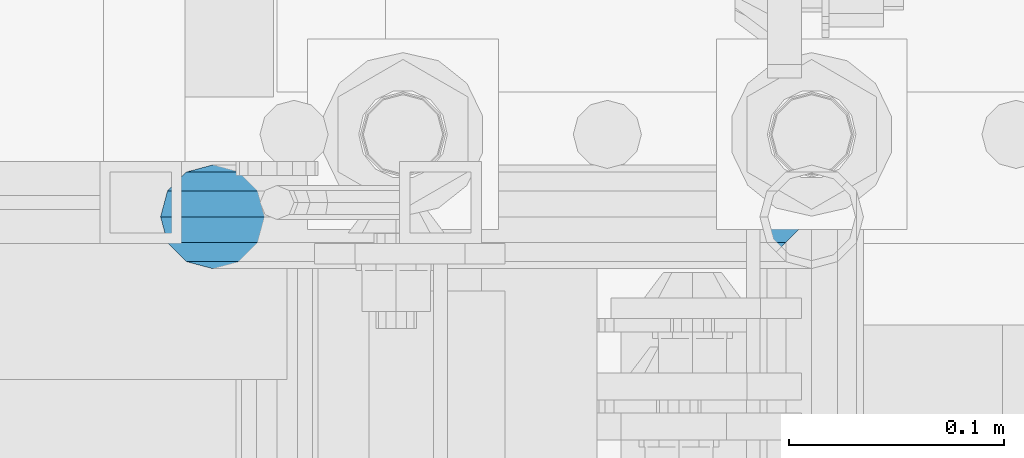
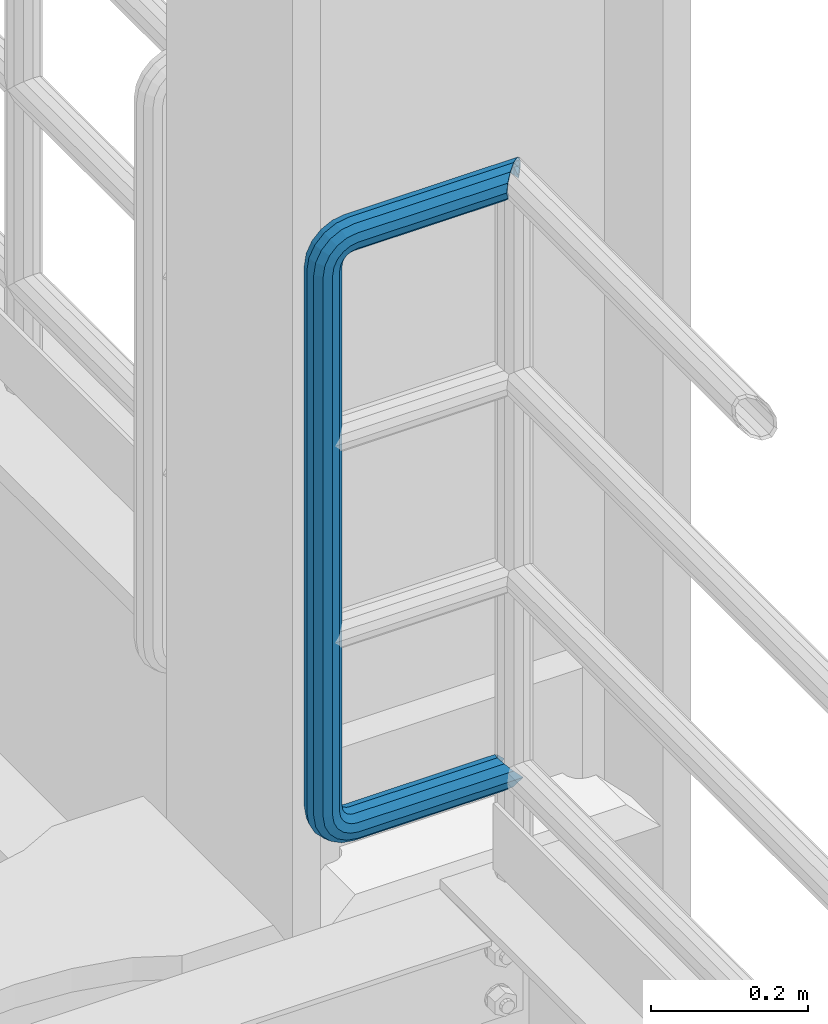
# One storey, part 994 of 1876: 1 beam, 1 element without a shape of its own.
"""IFC2X3 building model written with IfcOpenShell, lengths in millimetres."""

from ifc_helpers import new_model, si_unit, frame, origin_with_axes, place, context, subcontext, project, spatial, faceted_brep, material, type_object, element, aggregate, save


model = new_model("IFC2X3")

# Units and contexts
model_context = context("Model", 3, precision=1e-05, world=origin_with_axes())
body_context = subcontext(model_context, "Body", "Model", "MODEL_VIEW")
ifc_project = project(units=[si_unit("LENGTHUNIT", "METRE", prefix="MILLI"), si_unit("AREAUNIT", "SQUARE_METRE"), si_unit("VOLUMEUNIT", "CUBIC_METRE"), si_unit("MASSUNIT", "GRAM", prefix="KILO"), si_unit("TIMEUNIT", "SECOND"), si_unit("PLANEANGLEUNIT", "RADIAN"), si_unit("SOLIDANGLEUNIT", "STERADIAN"), si_unit("THERMODYNAMICTEMPERATUREUNIT", "DEGREE_CELSIUS"), si_unit("LUMINOUSINTENSITYUNIT", "LUMEN")], contexts=[model_context])

# Site, building, storey
site_placement = place(None, origin_with_axes())
site = spatial("IfcSite", under=ifc_project, at=site_placement, CompositionType="ELEMENT")
building_placement = place(site_placement, origin_with_axes())
building = spatial("IfcBuilding", under=site, at=building_placement, Name="Undefined", CompositionType="ELEMENT")
storey_placement = place(building_placement, origin_with_axes())
storey = spatial("IfcBuildingStorey", under=building, at=storey_placement, Name="Undefined", CompositionType="ELEMENT", Elevation=0.0)

# Assembly, beam
assembly_placement = place(storey_placement, origin_with_axes())
assembly = element("IfcElementAssembly", 1, at=assembly_placement, inside=storey, Name="RAIL", AssemblyPlace="NOTDEFINED", PredefinedType="RIGID_FRAME")
ifc_material = material()
beam_type = type_object("IfcBeamType", Name="PIPE1-1/2SCH40", PredefinedType="NOTDEFINED")
beam_placement = place(assembly_placement, frame((7620.0, -4788.2175, 9229.725), z_axis=(0.0, 0.0, 1.0), x_axis=(-1.0, 0.0, 0.0)))
beam = element("IfcBeam", 2, at=beam_placement, type_object=beam_type, material=ifc_material, Name="RAIL", ObjectType="PIPE1-1/2SCH40", context=body_context, shape_type="Brep", body=[
    faceted_brep([(16.4810964966631, 16.4810964966564, -11.4500249345219), (16.481099754581, 16.4810997545774, -16.4810932387409), (20.8971929933249, 12.0650000000005, -20.8971929933177), (20.8971929933249, 12.0650000000005, -15.8661214311796), (0.0, -24.1299999999992, 0.0), (12.0650000000014, -20.8971929933186, 0.0), (12.0650000000064, -20.8971929933177, -12.0649999999987), (-12.0650000000096, -20.8971929933177, -12.0649999999987), (-12.0649999999986, -20.8971929933186, 0.0), (-16.481093238739, -16.4810932387427, -16.4810997545756), (-16.4810964966554, -16.4810964966618, -11.4500249345183), (-15.2545715621367, -17.7076214311801, -10.2235000000001), (-12.5151929933171, -20.4470000000001, 0.0), (12.5151929933249, -20.4470000000001, 0.0), (20.8971929933249, -12.0650000000005, -15.8661214311796), (20.8971929933249, -12.0650000000005, -20.8971929933177), (15.2545715621445, -17.7076214311801, -10.2235000000001), (24.1300000000063, 0.0, -20.4470000000001), (24.1300000000063, 0.0, -24.130000000001), (21.3906214311868, -10.2235000000001, -17.7076214311819), (21.3906214311868, 10.2235000000001, -17.7076214311819), (1.20714750983051e-12, 24.1299999999974, -914.399963378906), (12.0650000000014, 20.8971929933159, -926.464963378905), (12.0650000000014, 20.8971929933177, -902.334963378908), (12.0650000000014, -20.8971929933195, -902.334963378908), (12.0650000000014, -20.8971929933195, -926.464963378905), (1.52133659548828e-12, -24.130000000001, -914.399963378906), (20.8971929933199, -12.0650000000023, -893.502770385589), (20.8971929933199, -12.0650000000005, -898.533841947723), (15.2545715621378, -17.7076214311819, -904.176463378906), (12.5151929933181, -20.4470000000019, -914.399963378906), (15.2545715621376, -17.7076214311819, -924.623463378906), (20.8971929933199, -12.0650000000005, -930.26608481009), (20.8971929933199, -12.0650000000023, -935.297156372224), (24.1300000000014, -1.81898940354586e-12, -934.846963378906), (24.1300000000014, -1.81898940354586e-12, -938.529963378907), (21.3906214311813, -10.2235000000019, -932.107584810088), (21.3906214311823, 10.2234999999982, -932.107584810088), (20.8971929933199, 12.0650000000005, -930.266084810086), (20.8971929933199, 12.0649999999987, -935.297156372224), (15.2545715621413, 17.7076214311783, -924.623463378906), (12.5151929933216, 20.4469999999983, -914.399963378906), (15.2545715621411, 17.7076214311783, -904.176463378906), (20.8971929933199, 12.0650000000005, -898.533841947727), (20.8971929933199, 12.0649999999987, -893.502770385589), (21.3906214311822, 10.2234999999982, -896.692341947724), (24.1300000000014, 0.0, -893.952963378906), (24.1300000000014, 0.0, -890.269963378905), (21.3906214311814, -10.2235000000019, -896.692341947724), (241.299995422363, -20.8971929933177, 12.0649999999987), (241.299995422363, -24.1299999999992, 0.0), (253.073542436527, -24.1299999999992, -1.86474665447167), (256.801832473661, -20.8971929933177, 9.60975021462946), (241.299995422363, -12.0650000000005, 20.8971929933177), (259.531130206197, -12.0650000000005, 18.0096649141014), (241.299995422363, 0.0, 24.130000000001), (260.530122510796, 0.0, 21.084247083727), (241.299995422363, 12.0650000000005, 20.8971929933177), (259.531130206197, 12.0650000000005, 18.0096649141014), (241.299995422363, 20.8971929933177, 12.0649999999987), (256.801832473661, 20.8971929933177, 9.60975021462946), (241.299995422363, 24.1299999999992, 0.0), (253.073542436527, 24.1299999999992, -1.86474665447167), (241.299995422363, 20.8971929933177, -12.0649999999987), (249.345252399393, 20.8971929933177, -13.3392435235728), (241.299995422363, 12.0650000000005, -20.8971929933177), (246.615954666858, 12.0650000000005, -21.7391582230448), (241.299995422363, 0.0, -24.130000000001), (245.616962362259, 0.0, -24.8137403926739), (241.299995422363, -12.0650000000005, -20.8971929933177), (246.615954666858, -12.0650000000005, -21.7391582230448), (241.299995422363, -20.8971929933177, -12.0649999999987), (249.345252399393, -20.8971929933177, -13.3392435235728), (267.334993896485, 20.8971929933177, -38.0999984741211), (279.399993896485, 24.1299999999992, -38.0999984741211), (279.399993896484, 24.1299999999992, -876.299964904785), (267.334993896484, 20.8971929933177, -876.299964904785), (291.464993896486, 20.8971929933177, -38.0999984741211), (291.464993896484, 20.8971929933177, -876.299964904785), (300.297186889804, 12.0650000000005, -38.0999984741211), (300.297186889803, 12.0650000000005, -876.299964904785), (303.529993896486, 0.0, -38.0999984741211), (303.529993896484, 0.0, -876.299964904785), (300.297186889804, -12.0650000000005, -38.0999984741211), (300.297186889803, -12.0650000000005, -876.299964904785), (291.464993896486, -20.8971929933177, -38.0999984741211), (291.464993896484, -20.8971929933177, -876.299964904785), (279.399993896484, -24.1299999999992, -38.0999984741211), (279.399993896484, -24.1299999999992, -876.299964904785), (267.334993896485, -20.8971929933177, -38.0999984741211), (267.334993896484, -20.8971929933177, -876.299964904785), (258.502800903167, -12.0650000000005, -38.0999984741211), (258.502800903166, -12.0650000000005, -876.299964904785), (255.269993896485, 0.0, -38.0999984741211), (255.269993896484, 0.0, -876.299964904785), (258.502800903167, 12.0650000000005, -38.0999984741211), (258.502800903166, 12.0650000000005, -876.299964904785), (257.660835673438, 12.0650000000005, -881.615924149282), (254.586253503809, 0.0, -880.616931844681), (257.660835673438, -12.0650000000005, -881.615924149282), (266.06075037291, -20.8971929933177, -884.345221881817), (277.535247242011, -24.130000000001, -888.073511918952), (289.009744111112, -20.8971929933195, -891.801801956084), (297.409658810584, -12.0650000000005, -894.531099688622), (300.484240980214, 0.0, -895.53009199322), (297.409658810584, 12.0650000000005, -894.531099688622), (289.009744111112, 20.8971929933177, -891.801801956084), (277.535247242011, 24.1299999999992, -888.073511918952), (266.06075037291, 20.8971929933177, -884.345221881817), (241.299995422364, -1.81898940354586e-12, -938.529963378911), (241.299995422364, -12.0650000000005, -935.297156372228), (241.299995422364, -20.8971929933195, -926.464963378909), (241.299995422363, -24.130000000001, -914.399963378906), (241.299995422363, -20.8971929933195, -902.334963378908), (241.299995422363, -12.0650000000005, -893.502770385589), (241.299995422363, 0.0, -890.269963378909), (241.299995422364, 20.8971929933177, -926.464963378909), (241.299995422364, 12.0649999999987, -935.297156372228), (241.299995422364, 24.1299999999992, -914.39996337891), (241.299995422363, 20.8971929933177, -902.334963378908), (241.299995422363, 12.0649999999987, -893.502770385589), (260.530122510801, 0.0, -935.484210462637), (259.531130206202, 12.0649999999987, -932.409628293008), (259.531130206201, -12.0650000000005, -932.409628293008), (256.801832473666, -20.8971929933195, -924.009713593536), (253.07354243653, -24.130000000001, -912.535216724435), (249.345252399395, -20.8971929933195, -901.060719855333), (246.615954666859, -12.0650000000005, -892.660805155861), (245.61696236226, 0.0, -889.586222986232), (246.615954666859, 12.0649999999987, -892.660805155861), (249.345252399395, 20.8971929933177, -901.060719855333), (253.07354243653, 24.1299999999992, -912.535216724435), (256.801832473666, 20.8971929933177, -924.009713593536), (275.977674493594, 12.0649999999987, -924.029695422345), (270.786241706733, 20.8971929933177, -916.884301193139), (277.877870775644, 0.0, -926.645091230272), (275.977674493608, -12.0650000000005, -924.029695422334), (270.786241706733, -20.8971929933195, -916.884301193139), (263.694612637823, -24.130000000001, -907.123511156005), (256.602983568912, -20.8971929933195, -897.362721118872), (251.411550782037, -12.0650000000005, -890.21732688968), (249.511354500001, 0.0, -887.601931081743), (251.411550782037, 12.0650000000005, -890.21732688968), (256.602983568912, 20.8971929933177, -897.362721118872), (263.694612637823, 24.1299999999992, -907.123511156005), (281.884331710718, 20.8971929933177, -905.786211189152), (272.123541673585, 24.1299999999992, -898.694582120243), (289.029725939912, 12.0650000000005, -910.977643976028), (291.645121747852, 0.0, -912.877840258065), (289.029725939912, -12.0650000000005, -910.977643976028), (281.884331710718, -20.8971929933195, -905.786211189152), (272.123541673585, -24.130000000001, -898.694582120243), (262.362751636451, -20.8971929933195, -891.602953051333), (255.217357407258, -12.0650000000005, -886.411520264461), (252.601961599318, 0.0, -884.511323982424), (255.217357407258, 12.0650000000005, -886.411520264461), (262.362751636451, 20.8971929933177, -891.602953051333), (266.060750372911, 20.8971929933177, -30.0547414970897), (257.660835673439, 12.0650000000005, -32.7840392296275), (277.535247242011, 24.1299999999992, -26.3264514599541), (289.009744111112, 20.8971929933177, -22.5981614228222), (297.409658810584, 12.0650000000005, -19.8688636902843), (300.484240980213, 0.0, -18.8698713856866), (297.409658810584, -12.0650000000005, -19.8688636902843), (289.009744111112, -20.8971929933177, -22.5981614228222), (277.535247242011, -24.1299999999992, -26.3264514599541), (266.060750372911, -20.8971929933177, -30.0547414970897), (257.660835673439, -12.0650000000005, -32.7840392296275), (254.58625350381, 0.0, -33.7830315342253), (255.217357407257, 12.0650000000005, -27.9884431144455), (252.601961599318, 0.0, -29.8886393964822), (262.362751636451, 20.8971929933177, -22.7970103275729), (272.123541673583, 24.1299999999992, -15.7053812586601), (281.884331710716, 20.8971929933177, -8.61375218975081), (289.029725939909, 12.0650000000005, -3.42231940287456), (291.645121747848, 0.0, -1.52212312084157), (289.029725939909, -12.0650000000005, -3.42231940287456), (281.884331710716, -20.8971929933177, -8.61375218975081), (272.123541673583, -24.1299999999992, -15.7053812586601), (262.362751636451, -20.8971929933177, -22.7970103275729), (255.217357407257, -12.0650000000005, -27.9884431144455), (249.511354500002, 0.0, -26.7980322971671), (251.411550782037, -12.0650000000005, -24.1826364892258), (251.411550782037, 12.0650000000005, -24.1826364892258), (256.602983568912, 20.8971929933177, -17.037242260034), (263.694612637822, 24.1299999999992, -7.27645222290084), (270.786241706732, 20.8971929933177, 2.48433781423228), (275.977674493607, 12.0650000000005, 9.62973204342416), (277.877870775642, 0.0, 12.2451278513654), (275.977674493607, -12.0650000000005, 9.62973204342416), (270.786241706732, -20.8971929933177, 2.48433781423228), (263.694612637822, -24.1299999999992, -7.27645222290084), (256.602983568912, -20.8971929933177, -17.037242260034), (20.8971929933232, 20.8971929933177, -12.0649999999987), (24.1300000000047, 24.1299999999992, 0.0), (20.8971929933232, 20.8971929933177, 12.0649999999987), (12.0650000000041, 12.0650000000005, 20.8971929933177), (-1.45519152283669e-11, 0.0, 24.130000000001), (-12.0649999999951, -12.0650000000005, 20.8971929933177), (-20.8971929933141, -20.8971929933177, 12.0649999999987), (-24.1299999999956, -24.1299999999992, 0.0), (-20.8971929933141, -20.8971929933177, -12.0649999999987), (-17.7076214311755, -17.7076214311801, -10.2235000000001), (-20.4469999999956, -20.4470000000001, 0.0), (-17.7076214311755, -17.7076214311801, 10.2235000000001), (241.299995422363, -17.7076214311801, 10.2235000000001), (241.299995422363, -20.4470000000001, 0.0), (241.299995422363, -17.7076214311801, -10.2235000000001), (241.299995422363, -10.2235000000001, -17.7076214311819), (241.299995422363, 0.0, -20.4470000000001), (241.299995422363, 0.0, 20.4470000000001), (241.299995422363, -10.2235000000001, 17.7076214311819), (-10.2234999999955, -10.2235000000001, 17.7076214311819), (-1.45519152283669e-11, 0.0, 20.4470000000001), (241.299995422363, 10.2235000000001, 17.7076214311819), (10.2235000000046, 10.2235000000001, 17.7076214311819), (241.299995422363, 17.7076214311801, 10.2235000000001), (17.7076214311846, 17.7076214311801, 10.2235000000001), (241.299995422363, 20.4470000000001, 0.0), (20.4470000000047, 20.4470000000001, 0.0), (241.299995422363, 17.7076214311801, -10.2235000000001), (17.7076214311846, 17.7076214311801, -10.2235000000001), (241.299995422363, 10.2235000000001, -17.7076214311819), (258.545498388721, -10.2235000000001, 14.9762020957387), (256.23277767852, -17.7076214311801, 7.85837963987069), (253.073542436527, -20.4470000000001, -1.86474665447167), (249.914307194535, -17.7076214311801, -11.5878729488177), (247.601586484334, -10.2235000000001, -18.7056954046857), (246.755071952542, 0.0, -21.31099924316), (247.601586484334, 10.2235000000001, -18.7056954046857), (249.914307194535, 17.7076214311801, -11.5878729488177), (253.073542436527, 20.4470000000001, -1.86474665447167), (256.23277767852, 17.7076214311801, 7.85837963987069), (258.545498388721, 10.2235000000001, 14.9762020957387), (259.392012920513, 0.0, 17.5815059342131), (275.713057691449, 0.0, 9.26551826108334), (274.10289136825, -10.2235000000001, 7.04931444488102), (274.10289136825, 10.2235000000001, 7.04931444488102), (269.703835164635, 17.7076214311801, 0.994533019089431), (263.694612637822, 20.4470000000001, -7.27645222290084), (257.685390111009, 17.7076214311801, -15.5474374648911), (253.286333907394, 10.2235000000001, -21.6022188906827), (251.676167584195, 0.0, -23.818422706885), (253.286333907394, -10.2235000000001, -21.6022188906827), (257.685390111009, -17.7076214311801, -15.5474374648911), (263.694612637822, -20.4470000000001, -7.27645222290084), (269.703835164635, -17.7076214311801, 0.994533019089431), (286.449308341364, -10.2235000000001, -5.29710252823133), (280.394526915574, -17.7076214311801, -9.69615873184739), (288.665512157566, 0.0, -3.68693620503473), (286.449308341364, 10.2235000000001, -5.29710252823133), (280.394526915574, 17.7076214311801, -9.69615873184739), (272.123541673583, 20.4470000000001, -15.7053812586601), (263.852556431592, 17.7076214311801, -21.7146037854764), (257.797775005802, 10.2235000000001, -26.1136599890888), (255.581571189601, 0.0, -27.723826312289), (257.797775005802, -10.2235000000001, -26.1136599890888), (263.852556431592, -17.7076214311801, -21.7146037854764), (272.123541673583, -20.4470000000001, -15.7053812586601), (287.258373536355, -17.7076214311801, -23.1672162179639), (277.535247242011, -20.4470000000001, -26.3264514599541), (294.376195992223, -10.2235000000001, -20.8544955077632), (296.981499830698, 0.0, -20.00798097597), (294.376195992223, 10.2235000000001, -20.8544955077632), (287.258373536355, 17.7076214311801, -23.1672162179639), (277.535247242011, 20.4470000000001, -26.3264514599541), (267.812120947668, 17.7076214311801, -29.485686701948), (260.6942984918, 10.2235000000001, -31.7984074121487), (258.088994653325, 0.0, -32.6449219439419), (260.6942984918, -10.2235000000001, -31.7984074121487), (267.812120947668, -17.7076214311801, -29.485686701948), (279.399993896484, -20.4470000000001, -38.0999984741211), (269.176493896485, -17.7076214311801, -38.0999984741211), (289.623493896486, -17.7076214311801, -38.0999984741211), (297.107615327666, -10.2235000000001, -38.0999984741211), (299.846993896486, 0.0, -38.0999984741211), (297.107615327666, 10.2235000000001, -38.0999984741211), (289.623493896486, 17.7076214311801, -38.0999984741211), (279.399993896485, 20.4470000000001, -38.0999984741211), (269.176493896485, 17.7076214311801, -38.0999984741211), (261.692372465305, 10.2235000000001, -38.0999984741211), (258.952993896485, 0.0, -38.0999984741211), (261.692372465305, -10.2235000000001, -38.0999984741211), (269.176493896484, -17.7076214311801, -876.299964904785), (261.692372465304, -10.2235000000001, -876.299964904785), (258.952993896484, 0.0, -876.299964904785), (261.692372465304, 10.2235000000001, -876.299964904785), (269.176493896484, 17.7076214311801, -876.299964904785), (279.399993896484, 20.4470000000001, -876.299964904785), (289.623493896484, 17.7076214311801, -876.299964904785), (297.107615327665, 10.2235000000001, -876.299964904785), (299.846993896484, 0.0, -876.299964904785), (297.107615327665, -10.2235000000001, -876.299964904785), (289.623493896484, -17.7076214311801, -876.299964904785), (279.399993896484, -20.4470000000001, -876.299964904785), (277.535247242011, -20.4470000000001, -888.073511918952), (267.812120947667, -17.7076214311801, -884.914276676958), (260.694298491799, -10.2235000000001, -882.601555966758), (258.088994653324, 0.0, -881.755041434964), (260.694298491799, 10.2235000000001, -882.601555966758), (267.812120947668, 17.7076214311801, -884.914276676958), (277.535247242011, 20.4470000000001, -888.073511918952), (287.258373536355, 17.7076214311801, -891.232747160942), (294.376195992223, 10.2235000000001, -893.545467871143), (296.981499830699, 0.0, -894.391982402936), (294.376195992223, -10.2235000000001, -893.545467871143), (287.258373536355, -17.7076214311801, -891.232747160942), (280.394526915577, -17.7076214311801, -904.703804647055), (272.123541673585, -20.4470000000001, -898.694582120243), (286.449308341367, -10.2235000000001, -909.102860850671), (288.665512157569, 0.0, -910.713027173868), (286.449308341367, 10.2235000000001, -909.102860850671), (280.394526915577, 17.7076214311801, -904.703804647055), (272.123541673585, 20.4470000000001, -898.694582120243), (263.852556431593, 17.7076214311801, -892.68535959343), (257.797775005802, 10.2235000000001, -888.286303389817), (255.581571189601, 0.0, -886.676137066617), (257.797775005802, -10.2235000000001, -888.286303389817), (263.852556431593, -17.7076214311801, -892.68535959343), (263.694612637823, -20.4470000000001, -907.123511156005), (257.685390111009, -17.7076214311801, -898.852525914015), (269.703835164636, -17.7076214311801, -915.394496397999), (274.102891368238, -10.2235000000001, -921.449277823798), (275.71305769145, 0.0, -923.66548163999), (274.102891368251, 10.2235000000001, -921.449277823787), (269.703835164636, 17.7076214311801, -915.394496397999), (263.694612637823, 20.4470000000001, -907.123511156005), (257.685390111009, 17.7076214311801, -898.852525914015), (253.286333907394, 10.2235000000001, -892.797744488227), (251.676167584195, 0.0, -890.581540672025), (253.286333907394, -10.2235000000001, -892.797744488227), (249.914307194537, -17.7076214311801, -902.812090430092), (247.601586484335, -10.2235000000001, -895.694267974224), (253.07354243653, -20.4470000000001, -912.535216724435), (256.232777678524, -17.7076214311819, -922.258343018777), (258.545498388725, -10.2235000000001, -929.376165474645), (259.392012920517, 0.0, -931.981469313119), (258.545498388725, 10.2235000000001, -929.376165474645), (256.232777678524, 17.7076214311801, -922.258343018777), (253.07354243653, 20.4470000000001, -912.535216724435), (249.914307194537, 17.7076214311801, -902.812090430092), (247.601586484335, 10.2235000000001, -895.694267974224), (246.755071952543, 0.0, -893.088964135746), (241.299995422363, -10.2235000000001, -896.692341947728), (241.299995422363, 0.0, -893.95296337891), (241.299995422363, -17.7076214311819, -904.17646337891), (241.299995422363, -20.4470000000001, -914.399963378906), (241.299995422364, -17.7076214311819, -924.62346337891), (241.299995422364, -10.2235000000001, -932.107584810088), (241.299995422364, -1.81898940354586e-12, -934.84696337891), (241.299995422364, 10.2234999999982, -932.107584810088), (241.299995422364, 17.7076214311801, -924.62346337891), (241.299995422364, 20.4470000000001, -914.39996337891), (241.299995422363, 17.7076214311801, -904.17646337891), (241.299995422363, 10.2235000000001, -896.692341947728)], [[[0, 1, 2, 3]], [[4, 5, 6]], [[7, 8, 4]], [[9, 10, 11, 12, 8, 7]], [[13, 5, 4, 8, 12]], [[14, 15, 6, 5, 13, 16]], [[17, 18, 15, 14, 19]], [[20, 3, 2, 18, 17]], [[21, 22, 23]], [[24, 25, 26]], [[27, 28, 29, 30, 31, 32, 33, 25, 24]], [[34, 35, 33, 32, 36]], [[37, 38, 39, 35, 34]], [[23, 22, 39, 38, 40, 41, 42, 43, 44]], [[44, 43, 45, 46, 47]], [[47, 46, 48, 28, 27]], [[49, 50, 51, 52]], [[53, 49, 52, 54]], [[55, 53, 54, 56]], [[57, 55, 56, 58]], [[59, 57, 58, 60]], [[61, 59, 60, 62]], [[63, 61, 62, 64]], [[65, 63, 64, 66]], [[67, 65, 66, 68]], [[69, 67, 68, 70]], [[71, 69, 70, 72]], [[73, 74, 75, 76]], [[74, 77, 78, 75]], [[77, 79, 80, 78]], [[79, 81, 82, 80]], [[81, 83, 84, 82]], [[83, 85, 86, 84]], [[85, 87, 88, 86]], [[87, 89, 90, 88]], [[89, 91, 92, 90]], [[91, 93, 94, 92]], [[93, 95, 96, 94]], [[94, 96, 97, 98]], [[92, 94, 98, 99]], [[90, 92, 99, 100]], [[88, 90, 100, 101]], [[86, 88, 101, 102]], [[84, 86, 102, 103]], [[82, 84, 103, 104]], [[80, 82, 104, 105]], [[78, 80, 105, 106]], [[75, 78, 106, 107]], [[76, 75, 107, 108]], [[109, 110, 33, 35]], [[110, 111, 25, 33]], [[111, 112, 26, 25]], [[112, 113, 24, 26]], [[113, 114, 27, 24]], [[114, 115, 47, 27]], [[116, 117, 39, 22]], [[118, 116, 22, 21]], [[119, 118, 21, 23]], [[120, 119, 23, 44]], [[115, 120, 44, 47]], [[117, 109, 35, 39]], [[121, 109, 117, 122]], [[123, 110, 109, 121]], [[124, 111, 110, 123]], [[125, 112, 111, 124]], [[126, 113, 112, 125]], [[127, 114, 113, 126]], [[128, 115, 114, 127]], [[129, 120, 115, 128]], [[130, 119, 120, 129]], [[131, 118, 119, 130]], [[132, 116, 118, 131]], [[122, 117, 116, 132]], [[133, 122, 132, 134]], [[135, 121, 122, 133]], [[136, 123, 121, 135]], [[137, 124, 123, 136]], [[138, 125, 124, 137]], [[139, 126, 125, 138]], [[140, 127, 126, 139]], [[141, 128, 127, 140]], [[142, 129, 128, 141]], [[143, 130, 129, 142]], [[144, 131, 130, 143]], [[134, 132, 131, 144]], [[145, 134, 144, 146]], [[147, 133, 134, 145]], [[148, 135, 133, 147]], [[149, 136, 135, 148]], [[150, 137, 136, 149]], [[151, 138, 137, 150]], [[152, 139, 138, 151]], [[153, 140, 139, 152]], [[154, 141, 140, 153]], [[155, 142, 141, 154]], [[156, 143, 142, 155]], [[146, 144, 143, 156]], [[107, 146, 156, 108]], [[106, 145, 146, 107]], [[105, 147, 145, 106]], [[104, 148, 147, 105]], [[103, 149, 148, 104]], [[102, 150, 149, 103]], [[101, 151, 150, 102]], [[100, 152, 151, 101]], [[99, 153, 152, 100]], [[98, 154, 153, 99]], [[97, 155, 154, 98]], [[108, 156, 155, 97]], [[96, 76, 108, 97]], [[95, 73, 76, 96]], [[157, 73, 95, 158]], [[159, 74, 73, 157]], [[160, 77, 74, 159]], [[161, 79, 77, 160]], [[162, 81, 79, 161]], [[163, 83, 81, 162]], [[164, 85, 83, 163]], [[165, 87, 85, 164]], [[166, 89, 87, 165]], [[167, 91, 89, 166]], [[168, 93, 91, 167]], [[158, 95, 93, 168]], [[169, 158, 168, 170]], [[171, 157, 158, 169]], [[172, 159, 157, 171]], [[173, 160, 159, 172]], [[174, 161, 160, 173]], [[175, 162, 161, 174]], [[176, 163, 162, 175]], [[177, 164, 163, 176]], [[178, 165, 164, 177]], [[179, 166, 165, 178]], [[180, 167, 166, 179]], [[170, 168, 167, 180]], [[181, 170, 180, 182]], [[183, 169, 170, 181]], [[184, 171, 169, 183]], [[185, 172, 171, 184]], [[186, 173, 172, 185]], [[187, 174, 173, 186]], [[188, 175, 174, 187]], [[189, 176, 175, 188]], [[190, 177, 176, 189]], [[191, 178, 177, 190]], [[192, 179, 178, 191]], [[182, 180, 179, 192]], [[70, 182, 192, 72]], [[68, 181, 182, 70]], [[66, 183, 181, 68]], [[64, 184, 183, 66]], [[62, 185, 184, 64]], [[60, 186, 185, 62]], [[58, 187, 186, 60]], [[56, 188, 187, 58]], [[54, 189, 188, 56]], [[52, 190, 189, 54]], [[51, 191, 190, 52]], [[72, 192, 191, 51]], [[50, 71, 72, 51]], [[71, 50, 4, 6]], [[69, 71, 6, 15]], [[67, 69, 15, 18]], [[65, 67, 18, 2]], [[193, 63, 65, 2, 1]], [[61, 63, 193, 194]], [[59, 61, 194, 195]], [[57, 59, 195, 196]], [[55, 57, 196, 197]], [[53, 55, 197, 198]], [[49, 53, 198, 199]], [[4, 50, 49, 199, 200]], [[200, 201, 7, 4]], [[201, 9, 7]], [[202, 11, 10]], [[202, 203, 12, 11]], [[203, 204, 205, 206, 13, 12]], [[206, 207, 16, 13]], [[16, 207, 208, 19, 14]], [[208, 209, 17, 19]], [[210, 211, 212, 213]], [[214, 210, 213, 215]], [[216, 214, 215, 217]], [[218, 216, 217, 219]], [[220, 218, 219, 221]], [[222, 220, 221, 0, 3, 20]], [[209, 222, 20, 17]], [[221, 219, 217, 215, 213, 212, 204, 203, 202, 10, 9, 201, 200, 199, 198, 197, 196, 195, 194, 193, 1, 0]], [[211, 205, 204, 212]], [[205, 211, 223, 224]], [[206, 205, 224, 225]], [[207, 206, 225, 226]], [[208, 207, 226, 227]], [[209, 208, 227, 228]], [[222, 209, 228, 229]], [[220, 222, 229, 230]], [[218, 220, 230, 231]], [[216, 218, 231, 232]], [[214, 216, 232, 233]], [[210, 214, 233, 234]], [[211, 210, 234, 223]], [[234, 235, 236, 223]], [[233, 237, 235, 234]], [[232, 238, 237, 233]], [[231, 239, 238, 232]], [[230, 240, 239, 231]], [[229, 241, 240, 230]], [[228, 242, 241, 229]], [[227, 243, 242, 228]], [[226, 244, 243, 227]], [[225, 245, 244, 226]], [[224, 246, 245, 225]], [[223, 236, 246, 224]], [[236, 247, 248, 246]], [[235, 249, 247, 236]], [[237, 250, 249, 235]], [[238, 251, 250, 237]], [[239, 252, 251, 238]], [[240, 253, 252, 239]], [[241, 254, 253, 240]], [[242, 255, 254, 241]], [[243, 256, 255, 242]], [[244, 257, 256, 243]], [[245, 258, 257, 244]], [[246, 248, 258, 245]], [[248, 259, 260, 258]], [[247, 261, 259, 248]], [[249, 262, 261, 247]], [[250, 263, 262, 249]], [[251, 264, 263, 250]], [[252, 265, 264, 251]], [[253, 266, 265, 252]], [[254, 267, 266, 253]], [[255, 268, 267, 254]], [[256, 269, 268, 255]], [[257, 270, 269, 256]], [[258, 260, 270, 257]], [[260, 271, 272, 270]], [[259, 273, 271, 260]], [[261, 274, 273, 259]], [[262, 275, 274, 261]], [[263, 276, 275, 262]], [[264, 277, 276, 263]], [[265, 278, 277, 264]], [[266, 279, 278, 265]], [[267, 280, 279, 266]], [[268, 281, 280, 267]], [[269, 282, 281, 268]], [[270, 272, 282, 269]], [[282, 272, 283, 284]], [[281, 282, 284, 285]], [[280, 281, 285, 286]], [[279, 280, 286, 287]], [[278, 279, 287, 288]], [[277, 278, 288, 289]], [[276, 277, 289, 290]], [[275, 276, 290, 291]], [[274, 275, 291, 292]], [[273, 274, 292, 293]], [[271, 273, 293, 294]], [[272, 271, 294, 283]], [[283, 294, 295, 296]], [[284, 283, 296, 297]], [[285, 284, 297, 298]], [[286, 285, 298, 299]], [[287, 286, 299, 300]], [[288, 287, 300, 301]], [[289, 288, 301, 302]], [[290, 289, 302, 303]], [[291, 290, 303, 304]], [[292, 291, 304, 305]], [[293, 292, 305, 306]], [[294, 293, 306, 295]], [[306, 307, 308, 295]], [[305, 309, 307, 306]], [[304, 310, 309, 305]], [[303, 311, 310, 304]], [[302, 312, 311, 303]], [[301, 313, 312, 302]], [[300, 314, 313, 301]], [[299, 315, 314, 300]], [[298, 316, 315, 299]], [[297, 317, 316, 298]], [[296, 318, 317, 297]], [[295, 308, 318, 296]], [[308, 319, 320, 318]], [[307, 321, 319, 308]], [[309, 322, 321, 307]], [[310, 323, 322, 309]], [[311, 324, 323, 310]], [[312, 325, 324, 311]], [[313, 326, 325, 312]], [[314, 327, 326, 313]], [[315, 328, 327, 314]], [[316, 329, 328, 315]], [[317, 330, 329, 316]], [[318, 320, 330, 317]], [[320, 331, 332, 330]], [[319, 333, 331, 320]], [[321, 334, 333, 319]], [[322, 335, 334, 321]], [[323, 336, 335, 322]], [[324, 337, 336, 323]], [[325, 338, 337, 324]], [[326, 339, 338, 325]], [[327, 340, 339, 326]], [[328, 341, 340, 327]], [[329, 342, 341, 328]], [[330, 332, 342, 329]], [[332, 343, 344, 342]], [[331, 345, 343, 332]], [[333, 346, 345, 331]], [[334, 347, 346, 333]], [[335, 348, 347, 334]], [[336, 349, 348, 335]], [[337, 350, 349, 336]], [[338, 351, 350, 337]], [[339, 352, 351, 338]], [[340, 353, 352, 339]], [[341, 354, 353, 340]], [[342, 344, 354, 341]], [[354, 344, 46, 45]], [[42, 353, 354, 45, 43]], [[352, 353, 42, 41]], [[351, 352, 41, 40]], [[350, 351, 40, 38, 37]], [[349, 350, 37, 34]], [[348, 349, 34, 36]], [[31, 347, 348, 36, 32]], [[346, 347, 31, 30]], [[345, 346, 30, 29]], [[343, 345, 29, 28, 48]], [[344, 343, 48, 46]]]),
])
aggregate(assembly, [beam])

save(model, "model.ifc")
